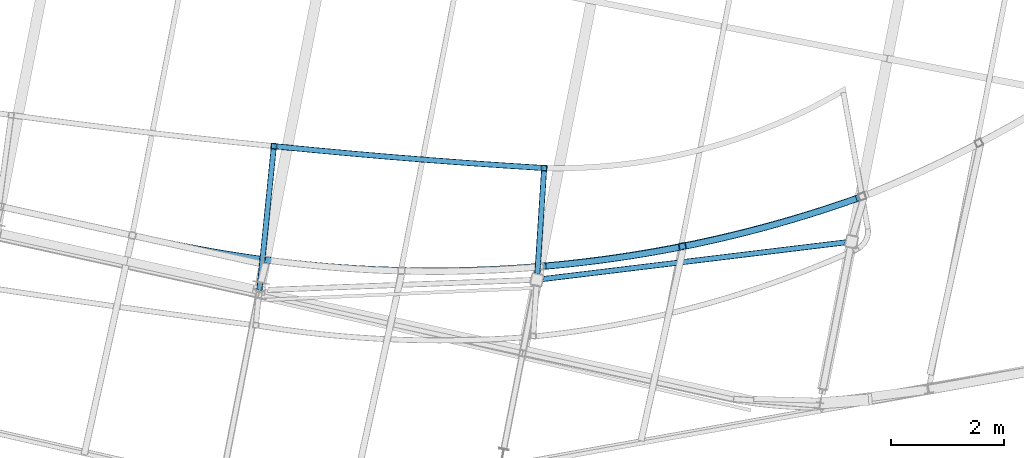
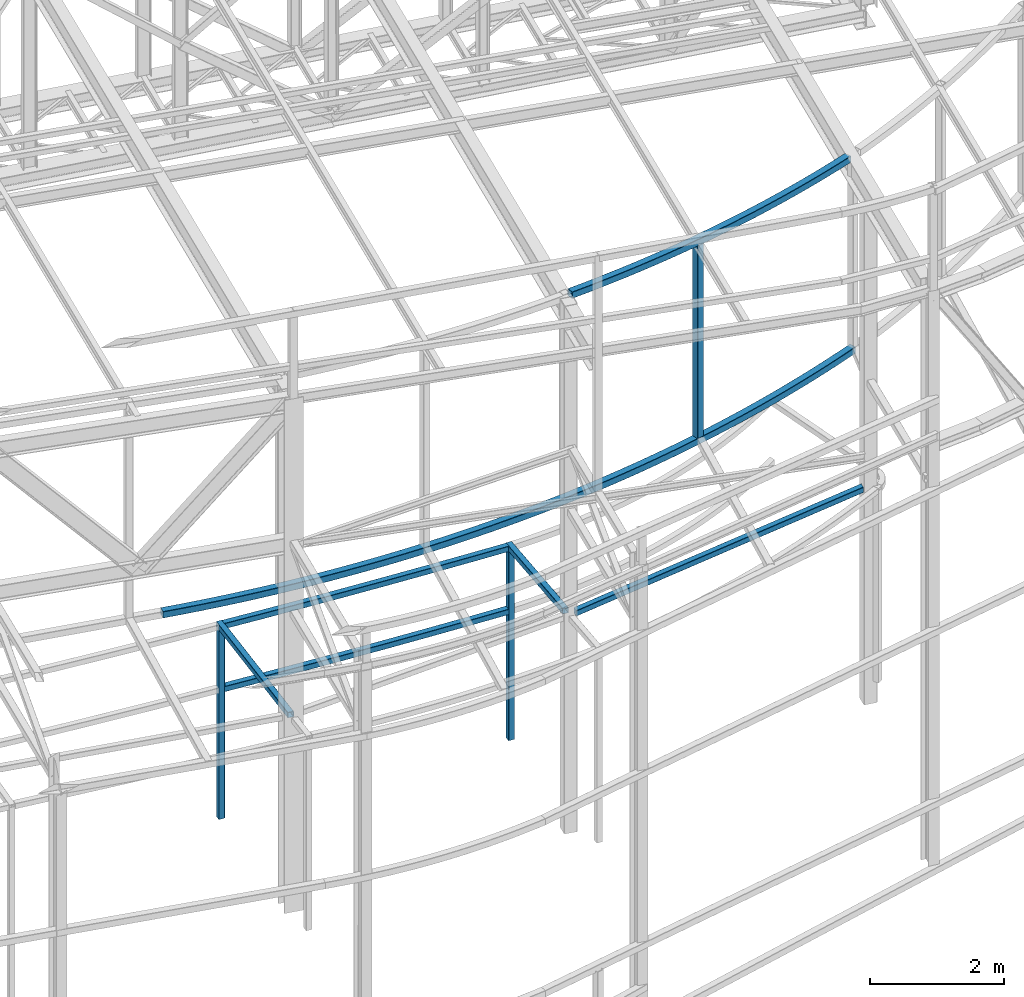
# One storey, part 53 of 215: 10 beams, 10 elements without a shape of their own.
"""IFC2X3 building model written with IfcOpenShell, lengths in millimetres."""

from ifc_helpers import new_model, entity, si_unit, frame, origin_with_axes, origin_2d_with_axis, place, context, subcontext, project, spatial, hollow_rectangle, extrude, clip, halfspace, material, type_object, element, aggregate, save


model = new_model("IFC2X3")

# Units and contexts
model_context = context("Model", 3, precision=1e-05, world=origin_with_axes())
body_context = subcontext(model_context, "Body", "Model", "MODEL_VIEW")
ifc_project = project(units=[si_unit("LENGTHUNIT", "METRE", prefix="MILLI"), si_unit("AREAUNIT", "SQUARE_METRE"), si_unit("VOLUMEUNIT", "CUBIC_METRE"), si_unit("MASSUNIT", "GRAM", prefix="KILO"), si_unit("TIMEUNIT", "SECOND"), si_unit("PLANEANGLEUNIT", "RADIAN"), si_unit("SOLIDANGLEUNIT", "STERADIAN"), si_unit("THERMODYNAMICTEMPERATUREUNIT", "DEGREE_CELSIUS"), si_unit("LUMINOUSINTENSITYUNIT", "LUMEN")], contexts=[model_context])

# Site, building, storey
site_placement = place(None, origin_with_axes())
site = spatial("IfcSite", under=ifc_project, at=site_placement, CompositionType="ELEMENT")
building_placement = place(site_placement, origin_with_axes())
building = spatial("IfcBuilding", under=site, at=building_placement, Name="Undefined", CompositionType="ELEMENT")
storey_placement = place(building_placement, origin_with_axes())
storey = spatial("IfcBuildingStorey", under=building, at=storey_placement, Name="Undefined", CompositionType="ELEMENT", Elevation=0.0)

# Assembly, beam
assembly_1_placement = place(storey_placement, origin_with_axes())
assembly_1 = element("IfcElementAssembly", 1, at=assembly_1_placement, inside=storey, Name="Steel Assembly", AssemblyPlace="NOTDEFINED", PredefinedType="RIGID_FRAME")
ifc_material = material(Name="STEEL/S275JR")
beam_type_1 = type_object("IfcBeamType", PredefinedType="NOTDEFINED")
beam_1_placement = place(assembly_1_placement, frame((74517.6363424721, 6320.69338826609, 5610.00000147687), z_axis=(0.0807598640368663, 0.996733587454916, 0.0), x_axis=(0.996733587454917, -0.0807598640368594, 0.0)))
beam_1 = element("IfcBeam", 2, at=beam_1_placement, type_object=beam_type_1, material=ifc_material, Name="POUTRE", context=body_context, shape_type="SweptSolid", body=[
    entity("IfcRevolvedAreaSolid", entity("IfcRectangleHollowProfileDef", "AREA", None, entity("IfcAxis2Placement2D", entity("IfcCartesianPoint", [0.0, 0.0]), entity("IfcDirection", [1.0, 0.0])), 100.0, 100.0, 4.0, 4.0, 8.0), entity("IfcAxis2Placement3D", entity("IfcCartesianPoint", [4790.57126055179, 0.0, 0.0]), entity("IfcDirection", [-0.999800765109305, 0.0, -0.0199607135856325]), entity("IfcDirection", [-6.93889390390723e-18, -1.0, -3.46944695195361e-18])), entity("IfcAxis1Placement", entity("IfcCartesianPoint", [0.0, 120000.0, 0.0]), entity("IfcDirection", [-1.0, 0.0, 0.0])), 0.039924078629625),
])
aggregate(assembly_1, [beam_1])

assembly_2_placement = place(storey_placement, origin_with_axes())
assembly_2 = element("IfcElementAssembly", 3, at=assembly_2_placement, inside=storey, Name="Steel Assembly", AssemblyPlace="NOTDEFINED", PredefinedType="RIGID_FRAME")
beam_2_placement = place(assembly_2_placement, frame((79166.3813249363, 3960.30384315345, 6760.00000147687), z_axis=(-0.120397820977231, 0.992725724812214, 0.0), x_axis=(0.992725724812214, 0.120397820977225, 0.0)))
beam_2 = element("IfcBeam", 4, at=beam_2_placement, type_object=beam_type_1, material=ifc_material, Name="POUTRE", context=body_context, shape_type="Clipping", body=[
    clip(clip(extrude(hollow_rectangle(XDim=100.0, YDim=100.0, WallThickness=4.0, InnerFilletRadius=4.0, OuterFilletRadius=8.0, at=origin_2d_with_axis()), frame((5515.28939964822, 0.0, -9.09494701772928e-13), z_axis=(-1.0, 0.0, 0.0), x_axis=(-6.93889390390723e-18, -1.0, -3.46944695195361e-18)), (0.0, 0.0, 1.0), 5434.5), halfspace(frame((5459.58493618995, -50.0, -70.6814765350555), z_axis=(0.951183815601405, 0.0, -0.308624932463262), x_axis=(-6.93889390390723e-18, -1.0, -3.46944695195361e-18)), False)), halfspace(frame((68.6836978494539, -50.0, -138.412520186935), z_axis=(0.951183815601405, 0.0, -0.308624932463262), x_axis=(-6.93889390390723e-18, -1.0, -3.46944695195361e-18)), True)),
])
aggregate(assembly_2, [beam_2])

assembly_3_placement = place(storey_placement, origin_with_axes())
assembly_3 = element("IfcElementAssembly", 5, at=assembly_3_placement, inside=storey, Name="Steel Assembly", AssemblyPlace="NOTDEFINED", PredefinedType="RIGID_FRAME")
beam_3_placement = place(assembly_3_placement, frame((74517.636342134, 6320.69338822117, 6760.00000147687), z_axis=(0.0807598640368663, 0.996733587454916, 0.0), x_axis=(0.996733587454917, -0.0807598640368594, 0.0)))
beam_3 = element("IfcBeam", 6, at=beam_3_placement, type_object=beam_type_1, material=ifc_material, Name="POUTRE", context=body_context, shape_type="SweptSolid", body=[
    entity("IfcRevolvedAreaSolid", entity("IfcRectangleHollowProfileDef", "AREA", None, entity("IfcAxis2Placement2D", entity("IfcCartesianPoint", [0.0, 0.0]), entity("IfcDirection", [1.0, 0.0])), 100.0, 100.0, 4.0, 4.0, 8.0), entity("IfcAxis2Placement3D", entity("IfcCartesianPoint", [4790.57126055179, 0.0, 0.0]), entity("IfcDirection", [-0.999800765109305, 0.0, -0.0199607135856325]), entity("IfcDirection", [-6.93889390390723e-18, -1.0, -3.46944695195361e-18])), entity("IfcAxis1Placement", entity("IfcCartesianPoint", [0.0, 120000.0, 0.0]), entity("IfcDirection", [-1.0, 0.0, 0.0])), 0.0399240786290659),
])
aggregate(assembly_3, [beam_3])

assembly_4_placement = place(storey_placement, origin_with_axes())
assembly_4 = element("IfcElementAssembly", 7, at=assembly_4_placement, inside=storey, Name="Steel Assembly", AssemblyPlace="NOTDEFINED", PredefinedType="RIGID_FRAME")
beam_4_placement = place(assembly_4_placement, frame((79292.5596210505, 5933.80750631125, 6760.00000147687), z_axis=(-0.99789749179923, 0.0648120039869599, 0.0), x_axis=(0.0, 0.0, -1.0)))
beam_4 = element("IfcBeam", 8, at=beam_4_placement, type_object=beam_type_1, material=ifc_material, Name="MONTANT", context=body_context, shape_type="SweptSolid", body=[
    extrude(hollow_rectangle(XDim=100.0, YDim=100.0, WallThickness=4.0, InnerFilletRadius=4.0, OuterFilletRadius=8.0, at=origin_2d_with_axis()), frame((3499.99999998675, 0.0, 0.0), z_axis=(-1.0, 0.0, 0.0), x_axis=(-6.93889390390723e-18, -1.0, -3.46944695195361e-18)), (0.0, 0.0, 1.0), 3500.0),
])
aggregate(assembly_4, [beam_4])

assembly_5_placement = place(storey_placement, origin_with_axes())
assembly_5 = element("IfcElementAssembly", 9, at=assembly_5_placement, inside=storey, Name="Steel Assembly", AssemblyPlace="NOTDEFINED", PredefinedType="RIGID_FRAME")
beam_5_placement = place(assembly_5_placement, frame((79177.3404846454, 4159.80803613803, 6760.00000147687), z_axis=(-0.99789749179923, 0.0648120039869599, 0.0), x_axis=(0.0648122369783522, 0.997897476666748, 0.0)))
beam_5 = element("IfcBeam", 10, at=beam_5_placement, type_object=beam_type_1, material=ifc_material, Name="POUTRE", context=body_context, shape_type="Clipping", body=[
    clip(extrude(hollow_rectangle(XDim=100.0, YDim=100.0, WallThickness=4.0, InnerFilletRadius=4.0, OuterFilletRadius=8.0, at=origin_2d_with_axis()), frame((1827.73720484615, -9.09494701772928e-13, 0.0), z_axis=(-1.0, 0.0, 0.0), x_axis=(-6.93889390390723e-18, -1.0, -3.46944695195361e-18)), (0.0, 0.0, 1.0), 1936.3), halfspace(frame((-76.8394109010133, -50.0000000000009, 95.0340487971407), z_axis=(-0.991793788825609, 0.0, 0.127847880103437), x_axis=(-6.93889390390723e-18, -1.0, -3.46944695195361e-18)), False)),
])
aggregate(assembly_5, [beam_5])

assembly_6_placement = place(storey_placement, origin_with_axes())
assembly_6 = element("IfcElementAssembly", 11, at=assembly_6_placement, inside=storey, Name="Steel Assembly", AssemblyPlace="NOTDEFINED", PredefinedType="RIGID_FRAME")
beam_6_placement = place(assembly_6_placement, frame((74517.636342134, 6320.69338822117, 6760.00000147687), z_axis=(-0.994954911339962, 0.10032310003428, 0.0), x_axis=(0.0, 0.0, -1.0)))
beam_6 = element("IfcBeam", 12, at=beam_6_placement, type_object=beam_type_1, material=ifc_material, Name="MONTANT", context=body_context, shape_type="SweptSolid", body=[
    extrude(hollow_rectangle(XDim=100.0, YDim=100.0, WallThickness=4.0, InnerFilletRadius=4.0, OuterFilletRadius=8.0, at=origin_2d_with_axis()), frame((3499.99999998675, 0.0, 0.0), z_axis=(-1.0, 0.0, 0.0), x_axis=(-6.93889390390723e-18, -1.0, -3.46944695195361e-18)), (0.0, 0.0, 1.0), 3500.0),
])
aggregate(assembly_6, [beam_6])

assembly_7_placement = place(storey_placement, origin_with_axes())
assembly_7 = element("IfcElementAssembly", 13, at=assembly_7_placement, inside=storey, Name="Steel Assembly", AssemblyPlace="NOTDEFINED", PredefinedType="RIGID_FRAME")
beam_7_placement = place(assembly_7_placement, frame((74281.0578548365, 3974.43049778141, 6760.00000147687), z_axis=(-0.994954911339962, 0.10032310003428, 0.0), x_axis=(0.100323331995049, 0.994954887950912, 0.0)))
beam_7 = element("IfcBeam", 14, at=beam_7_placement, type_object=beam_type_1, material=ifc_material, Name="POUTRE", context=body_context, shape_type="Clipping", body=[
    clip(extrude(hollow_rectangle(XDim=100.0, YDim=100.0, WallThickness=4.0, InnerFilletRadius=4.0, OuterFilletRadius=8.0, at=origin_2d_with_axis()), frame((2408.16007338086, 0.0, 3.34199345056305e-14), z_axis=(-1.0, 0.0, 0.0), x_axis=(-6.93889390390723e-18, -1.0, -3.46944695195361e-18)), (0.0, 0.0, 1.0), 2628.6), halfspace(frame((-195.768188716298, -50.0, -0.392837131090346), z_axis=(0.995719001553571, 0.0, -0.092431974690363), x_axis=(-6.93889390390723e-18, -1.0, -3.46944695195361e-18)), True)),
])
aggregate(assembly_7, [beam_7])

assembly_8_placement = place(storey_placement, origin_with_axes())
assembly_8 = element("IfcElementAssembly", 15, at=assembly_8_placement, inside=storey, Name="Steel Assembly", AssemblyPlace="NOTDEFINED", PredefinedType="RIGID_FRAME")
beam_type_2 = type_object("IfcBeamType", PredefinedType="NOTDEFINED")
beam_8_placement = place(assembly_8_placement, frame((84911.6527930805, 5431.4195152733, 8706.00009389638), z_axis=(0.0, 0.0, -1.0), x_axis=(-0.997918929152116, -0.0644810890098291, 6.999999997299e-09)))
beam_8 = element("IfcBeam", 16, at=beam_8_placement, type_object=beam_type_2, material=ifc_material, Name="LISSE", context=body_context, shape_type="SweptSolid", body=[
    entity("IfcRevolvedAreaSolid", entity("IfcRectangleHollowProfileDef", "AREA", None, entity("IfcAxis2Placement2D", entity("IfcCartesianPoint", [0.0, 0.0]), entity("IfcDirection", [1.0, 0.0])), 120.0, 120.0, 5.0, 5.0, 10.0), entity("IfcAxis2Placement3D", entity("IfcCartesianPoint", [12408.9632969254, 1.79898672957393e-13, 1.81898940354586e-12]), entity("IfcDirection", [-0.961438119292109, -0.2750213496659, 0.0]), entity("IfcDirection", [0.2750213496659, -0.961438119292109, 0.0])), entity("IfcAxis1Placement", entity("IfcCartesianPoint", [-22560.0, 0.0, 0.0]), entity("IfcDirection", [-6.93889390390723e-18, -1.0, -3.46944695195361e-18])), 0.557223816581973),
])
aggregate(assembly_8, [beam_8])

assembly_9_placement = place(storey_placement, origin_with_axes())
assembly_9 = element("IfcElementAssembly", 17, at=assembly_9_placement, inside=storey, Name="Steel Assembly", AssemblyPlace="NOTDEFINED", PredefinedType="RIGID_FRAME")
beam_9_placement = place(assembly_9_placement, frame((81733.5969207, 4551.55041084225, 12392.9797171584), z_axis=(0.190527922929833, -0.98168177663846, 1.00000033816747e-09), x_axis=(0.0, 0.0, -1.0)))
beam_9 = element("IfcBeam", 18, at=beam_9_placement, type_object=beam_type_2, material=ifc_material, Name="LISSE", context=body_context, shape_type="SweptSolid", body=[
    extrude(hollow_rectangle(XDim=120.0, YDim=120.0, WallThickness=5.0, InnerFilletRadius=5.0, OuterFilletRadius=10.0, at=origin_2d_with_axis()), frame((3626.97891900463, 1.45519152043655e-11, -1.81898939942063e-12), z_axis=(-1.0, 0.0, 0.0), x_axis=(-6.93889390390723e-18, -1.0, -3.46944695195361e-18)), (0.0, 0.0, 1.0), 3627.0),
])
aggregate(assembly_9, [beam_9])

assembly_10_placement = place(storey_placement, origin_with_axes())
assembly_10 = element("IfcElementAssembly", 19, at=assembly_10_placement, inside=storey, Name="Steel Assembly", AssemblyPlace="NOTDEFINED", PredefinedType="RIGID_FRAME")
beam_10_placement = place(assembly_10_placement, frame((84804.5857010901, 5392.19900350884, 12246.6913450285), z_axis=(-0.0287830269937704, -0.00625120399864769, -0.999566135783743), x_axis=(-0.976794780093825, -0.212142446020377, 0.0294540350028294)))
beam_10 = element("IfcBeam", 20, at=beam_10_placement, type_object=beam_type_2, material=ifc_material, Name="LISSE", context=body_context, shape_type="SweptSolid", body=[
    entity("IfcRevolvedAreaSolid", entity("IfcRectangleHollowProfileDef", "AREA", None, entity("IfcAxis2Placement2D", entity("IfcCartesianPoint", [0.0, 0.0]), entity("IfcDirection", [1.0, 0.0])), 120.0, 120.0, 5.0, 5.0, 10.0), entity("IfcAxis2Placement3D", entity("IfcCartesianPoint", [5611.26703075925, -1.90072774097403e-12, -3.63797880709171e-12]), entity("IfcDirection", [-0.991879405508576, -0.127181936327273, 1.11093768188698e-19]), entity("IfcDirection", [0.127181936327273, -0.991879405508576, 8.66409365424046e-19])), entity("IfcAxis1Placement", entity("IfcCartesianPoint", [-22060.0, 0.0, 0.0]), entity("IfcDirection", [-6.93889390390723e-18, -1.0, -3.46944695195361e-18])), 0.25505464559207),
])
aggregate(assembly_10, [beam_10])

save(model, "model.ifc")
